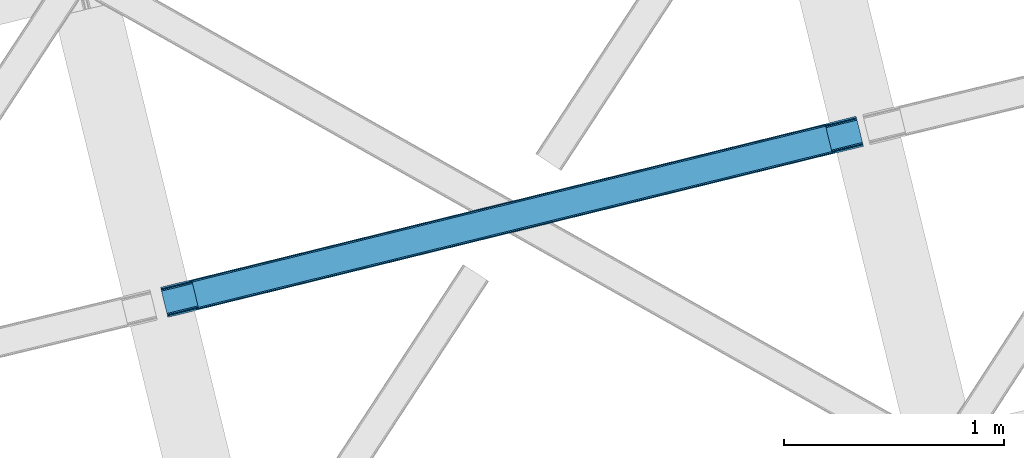
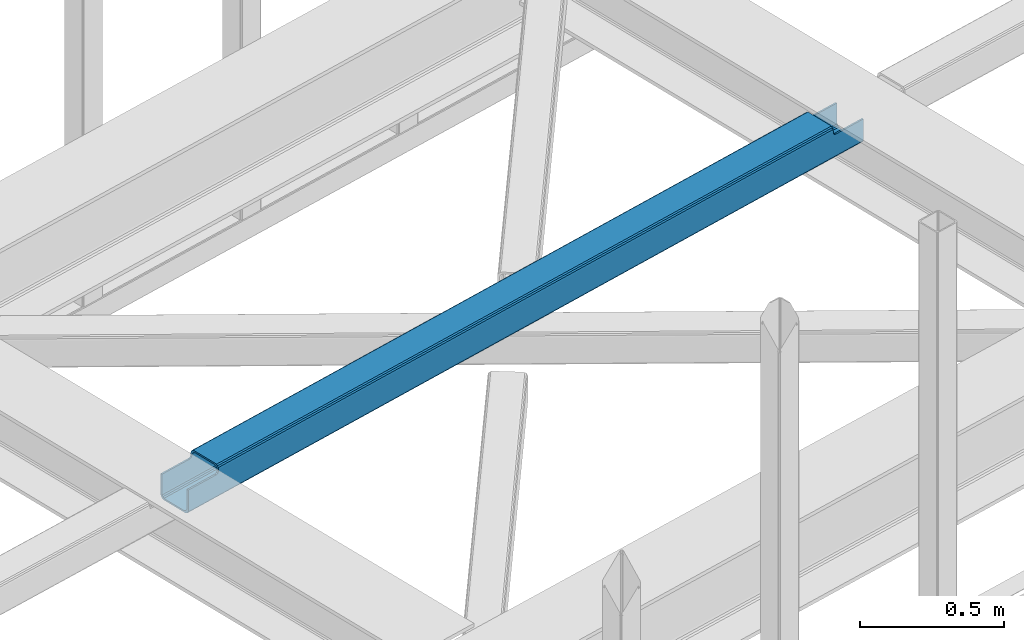
# One storey, part 34 of 67: 1 beam.
"""IFC4 building model written with IfcOpenShell, lengths in millimetres."""

from ifc_helpers import new_model, entity, si_unit, converted_unit, derived_unit, direction, frame, origin, place, context, subcontext, project, spatial, triangles, type_object, element, save


model = new_model("IFC4")

# Units and contexts
model_context = context("Model", 3, precision=0.01, world=origin(), true_north=direction((6.12303176911189e-17, 1.0)))
plan_context = context("Plan", 3, precision=0.01, world=origin(), true_north=direction((6.12303176911189e-17, 1.0)))
body_context = subcontext(model_context, "Body", "Model", "MODEL_VIEW")
ifc_project = project(units=[si_unit("LENGTHUNIT", "METRE", prefix="MILLI"), si_unit("AREAUNIT", "SQUARE_METRE"), si_unit("VOLUMEUNIT", "CUBIC_METRE"), converted_unit("PLANEANGLEUNIT", "DEGREE", entity("IfcRatioMeasure", 0.0174532925199433), si_unit("PLANEANGLEUNIT", "RADIAN"), dimensions=[0, 0, 0, 0, 0, 0, 0]), si_unit("MASSUNIT", "GRAM", prefix="KILO"), derived_unit("MASSDENSITYUNIT", [(si_unit("MASSUNIT", "GRAM", prefix="KILO"), 1), (si_unit("LENGTHUNIT", "METRE"), -3)]), derived_unit("MOMENTOFINERTIAUNIT", [(si_unit("LENGTHUNIT", "METRE"), 4)]), si_unit("TIMEUNIT", "SECOND"), si_unit("FREQUENCYUNIT", "HERTZ"), si_unit("THERMODYNAMICTEMPERATUREUNIT", "DEGREE_CELSIUS"), derived_unit("THERMALTRANSMITTANCEUNIT", [(si_unit("MASSUNIT", "GRAM", prefix="KILO"), 1), (si_unit("THERMODYNAMICTEMPERATUREUNIT", "KELVIN"), -1), (si_unit("TIMEUNIT", "SECOND"), -3)]), derived_unit("VOLUMETRICFLOWRATEUNIT", [(si_unit("LENGTHUNIT", "METRE"), 3), (si_unit("TIMEUNIT", "SECOND"), -1)]), derived_unit("MASSFLOWRATEUNIT", [(si_unit("MASSUNIT", "GRAM", prefix="KILO"), 1), (si_unit("TIMEUNIT", "SECOND"), -1)]), derived_unit("ROTATIONALFREQUENCYUNIT", [(si_unit("TIMEUNIT", "SECOND"), -1)]), si_unit("ELECTRICCURRENTUNIT", "AMPERE"), si_unit("ELECTRICVOLTAGEUNIT", "VOLT"), si_unit("POWERUNIT", "WATT"), si_unit("FORCEUNIT", "NEWTON", prefix="KILO"), si_unit("ILLUMINANCEUNIT", "LUX"), si_unit("LUMINOUSFLUXUNIT", "LUMEN"), si_unit("LUMINOUSINTENSITYUNIT", "CANDELA"), derived_unit("USERDEFINED", [(si_unit("MASSUNIT", "GRAM", prefix="KILO"), -1), (si_unit("LENGTHUNIT", "METRE"), -2), (si_unit("TIMEUNIT", "SECOND"), 3), (si_unit("LUMINOUSFLUXUNIT", "LUMEN"), 1)]), derived_unit("LINEARVELOCITYUNIT", [(si_unit("LENGTHUNIT", "METRE"), 1), (si_unit("TIMEUNIT", "SECOND"), -1)]), si_unit("PRESSUREUNIT", "PASCAL"), derived_unit("USERDEFINED", [(si_unit("LENGTHUNIT", "METRE"), -2), (si_unit("MASSUNIT", "GRAM", prefix="KILO"), 1), (si_unit("TIMEUNIT", "SECOND"), -2)]), derived_unit("LINEARFORCEUNIT", [(si_unit("MASSUNIT", "GRAM", prefix="KILO"), 1), (si_unit("LENGTHUNIT", "METRE"), 1), (si_unit("TIMEUNIT", "SECOND"), -2), (si_unit("LENGTHUNIT", "METRE"), -1)]), derived_unit("PLANARFORCEUNIT", [(si_unit("MASSUNIT", "GRAM", prefix="KILO"), 1), (si_unit("LENGTHUNIT", "METRE"), 1), (si_unit("TIMEUNIT", "SECOND"), -2), (si_unit("LENGTHUNIT", "METRE"), -2)])], contexts=[model_context, plan_context])

# Site, building, storey
site_placement = place(None, origin())
site = spatial("IfcSite", under=ifc_project, at=site_placement, CompositionType="ELEMENT")
building_placement = place(site_placement, origin())
building = spatial("IfcBuilding", under=site, at=building_placement, CompositionType="ELEMENT")
storey_placement = place(building_placement, frame((0.0, 0.0, 19800.0)))
storey = spatial("IfcBuildingStorey", under=building, at=storey_placement, CompositionType="ELEMENT", Elevation=19800.0)

# Beam
beam_type = type_object("IfcBeamType", PredefinedType="BEAM")
beam_placement = place(storey_placement, frame((-36151.9096069336, 10320.6374816895, 3967.02835693359)))
element("IfcBeam", 1, at=beam_placement, inside=storey, type_object=beam_type, ObjectType="Steel Beam", PredefinedType="BEAM", context=body_context, shape_type="Tessellation", body=[
    triangles([(3160.10943603516, 895.15698852539, 0.0), (3184.97536010742, 793.143447875977, 0.0), (4.14393310546438, 119.014828491212, 0.965057373046875), (29.012182617189, 17.0012878417965, 0.965057373046875), (3155.96550292968, 912.159439086914, 17.4989318847656), (3156.27943725586, 910.86533203125, 10.8016662597656), (0.0, 136.017279052734, 18.4639892578125), (0.316259765626455, 134.723171997071, 11.7667236328125), (3157.17938232422, 907.179510498047, 5.12526855468604), (1.21387939452688, 131.037350463868, 6.09032592773292), (3158.52348632812, 901.663568115235, 1.33247680664135), (2.5579833984375, 125.521408081055, 2.29753417968823), (3186.56130981445, 786.636868286134, 1.33247680664135), (30.5981323242158, 10.4947082519539, 2.29753417968823), (3187.90773925781, 781.12092590332, 5.12526855468604), (31.9422363281265, 4.97876586914026, 6.09032592773292), (3188.80535888672, 777.436267089844, 10.8016662597656), (32.8398559570269, 1.29410705566443, 11.7667236328125), (3189.12161865235, 776.140997314453, 17.4989318847656), (33.1561157226533, 0.0, 18.4639892578125), (2.87191772460938, 124.236602783203, 13.0898986816392), (4.21602172851271, 118.720660400391, 9.29710693359448), (5.80197143554688, 112.214080810547, 7.96463012695313), (1.97429809570167, 127.922424316406, 18.7662963867188), (0.0, 136.017279052734, 105.472631835935), (1.65803833007521, 129.216531372071, 25.4635620117188), (1.65803833007521, 129.216531372071, 105.472631835935), (28.9400939941406, 17.2966186523445, 9.29710693359448), (30.284197998044, 11.7806762695309, 13.0898986816392), (27.3541442871065, 23.8020355224617, 7.96463012695313), (31.1818176269517, 8.09485473632776, 18.7662963867188), (31.4980773925781, 6.80074768066515, 25.4635620117188), (33.1561157226533, 0.0, 105.472631835935), (31.4980773925781, 6.80074768066515, 105.472631835935), (3183.3196472168, 799.944195556642, 6.99957275390625), (3161.76747436523, 888.356240844727, 6.99957275390625), (3160.1815246582, 894.862820434571, 8.3320495605476), (3158.83742065429, 900.378762817383, 12.1248413085923), (3157.93747558594, 904.064584350586, 17.8035644531228), (3157.62354125977, 905.358691406251, 24.4985046386719), (3187.46358032226, 782.942907714843, 24.4985046386719), (3187.14732055664, 784.237014770508, 17.8035644531228), (3186.24970092774, 787.922836303711, 12.1248413085923), (3184.90559692383, 793.438778686525, 8.3320495605476), (131.782653808594, 161.216903686523, 105.472631835935), (130.124615478511, 168.018814086914, 105.472631835935), (163.280731201172, 32.0003723144528, 105.472631835935), (161.622692871089, 38.8011199951179, 105.472631835935), (3155.96550292968, 912.159439086914, 104.491296386717), (3157.62354125977, 905.358691406251, 104.491296386717), (3189.12161865235, 776.140997314453, 104.491296386717), (3187.46358032226, 782.942907714843, 104.491296386717), (3025.84321289062, 880.157904052734, 104.491296386717), (3027.5012512207, 873.357156372071, 104.491296386717), (3057.3412902832, 750.941372680665, 104.491296386717), (3058.99932861328, 744.140625, 104.491296386717), (3022.06437377929, 879.228890991211, 106.102825927734), (3023.72241210938, 872.428143310548, 106.102825927734), (3018.29018554687, 878.301040649414, 107.71435546875), (3019.94822387695, 871.500292968751, 107.71435546875), (3016.72516479492, 877.916180419923, 111.602490234374), (3018.383203125, 871.115432739258, 111.602490234374), (3015.16246948242, 877.53132019043, 115.492950439453), (3016.8205078125, 870.730572509767, 115.541784667967), (3049.88128051758, 741.898901367187, 111.602490234374), (3048.2232421875, 748.699649047852, 111.602490234374), (3046.660546875, 748.314788818359, 115.492950439453), (3048.31858520507, 741.514041137696, 115.492950439453), (3051.44630126953, 742.28376159668, 107.71435546875), (3049.78826293945, 749.084509277343, 107.71435546875), (3055.22048950195, 743.211611938477, 106.102825927734), (3053.56245117187, 750.012359619141, 106.102825927734), (140.910003662109, 163.462115478516, 112.581500244141), (142.463397216794, 163.844650268555, 116.471960449217), (139.335681152341, 163.074929809571, 108.693365478513), (135.556842041013, 162.145916748048, 107.081835937501), (170.750042724605, 41.046331787109, 112.581500244141), (169.175720214844, 40.6591461181652, 108.693365478513), (165.39920654297, 39.7301330566406, 107.081835937501), (172.303436279297, 41.4288665771492, 116.471960449217), (139.240338134761, 170.260537719727, 112.583825683592), (140.805358886719, 170.64539794922, 116.471960449217), (137.677642822266, 169.875677490234, 108.693365478513), (133.901129150392, 168.946664428711, 107.081835937501), (170.833758544919, 33.8583984375, 108.693365478513), (172.396453857422, 34.2420959472656, 112.583825683592), (173.961474609372, 34.6269561767585, 116.471960449217), (167.054919433591, 32.9293853759773, 107.081835937501), (3015.16246948242, 877.53132019043, 122.541357421873), (140.805358886719, 170.64539794922, 123.420373535155), (3048.31858520507, 741.514041137696, 122.541357421873), (173.961474609372, 34.6269561767585, 123.420373535155), (3017.13444213867, 869.436465454102, 122.239050292967), (142.77965698242, 162.55054321289, 123.118066406249), (3018.03438720703, 865.750643920899, 127.917773437501), (143.677276611328, 158.864721679687, 128.794464111328), (3019.37849121093, 860.234701538086, 131.710565185545), (145.021380615231, 153.348779296875, 132.589581298827), (3020.96444091797, 853.728121948243, 133.043041992187), (146.607330322266, 146.842199707031, 133.922058105469), (3046.34428710937, 749.608895874024, 122.239050292967), (171.98717651367, 42.7229736328136, 123.118066406249), (3042.51661376953, 765.317239379883, 133.043041992187), (3044.10256347656, 758.810659790039, 131.710565185545), (168.159503173825, 58.4301544189457, 133.922058105469), (169.745452880859, 51.9247375488285, 132.589581298827), (3045.44666748046, 753.294717407227, 127.917773437501), (171.089556884763, 46.4087951660167, 128.796789550779), (3015.47640380859, 876.237213134766, 129.238623046873), (3016.37634887695, 872.551391601563, 134.917346191407), (3017.72045288086, 867.035449218751, 138.710137939452), (3019.30640258789, 860.530032348634, 140.042614746093), (3045.75827636719, 752.009912109375, 138.710137939452), (3044.17232666015, 758.51649169922, 140.042614746093), (3047.10470581055, 746.493969726564, 134.917346191407), (3048.00232543945, 742.80814819336, 129.238623046873), (141.121618652345, 169.351290893555, 130.117639160155), (142.019238281246, 165.665469360352, 135.796362304685), (143.363342285156, 160.149526977539, 139.589154052734), (144.949291992183, 153.642947387696, 140.921630859375), (171.403491210935, 45.1228271484379, 139.589154052734), (169.817541503908, 51.6294067382823, 140.921630859375), (172.747595214845, 39.6068847656261, 135.796362304685), (173.645214843746, 35.9222259521484, 130.117639160155)], [[1, 2, 3], [4, 3, 2], [5, 6, 7], [8, 7, 6], [6, 9, 8], [10, 8, 9], [9, 11, 10], [12, 10, 11], [11, 1, 12], [3, 12, 1], [2, 13, 4], [14, 4, 13], [13, 15, 14], [16, 14, 15], [15, 17, 16], [18, 16, 17], [17, 19, 18], [20, 18, 19], [21, 8, 10], [21, 10, 12], [21, 12, 22], [23, 3, 4], [3, 22, 12], [23, 22, 3], [8, 24, 7], [25, 26, 27], [25, 7, 26], [8, 21, 24], [24, 26, 7], [28, 14, 29], [4, 30, 23], [28, 4, 14], [4, 28, 30], [16, 18, 29], [29, 14, 16], [18, 31, 29], [32, 31, 20], [20, 31, 18], [32, 33, 34], [20, 33, 32], [35, 36, 23], [23, 30, 35], [36, 37, 22], [22, 23, 36], [37, 38, 21], [21, 22, 37], [38, 39, 24], [24, 21, 38], [39, 40, 26], [26, 24, 39], [41, 42, 31], [31, 32, 41], [42, 43, 29], [29, 31, 42], [43, 44, 28], [28, 29, 43], [44, 35, 30], [30, 28, 44], [45, 46, 25], [25, 27, 45], [47, 48, 34], [34, 33, 47], [6, 5, 39], [49, 40, 5], [40, 49, 50], [40, 39, 5], [38, 6, 39], [38, 9, 6], [11, 38, 37], [38, 11, 9], [37, 1, 11], [1, 36, 2], [36, 1, 37], [17, 43, 42], [42, 19, 17], [42, 41, 19], [41, 51, 19], [52, 51, 41], [44, 43, 13], [2, 44, 13], [35, 2, 36], [2, 35, 44], [13, 43, 15], [15, 43, 17], [50, 49, 53], [53, 54, 50], [51, 52, 55], [55, 56, 51], [54, 53, 57], [57, 58, 54], [58, 57, 59], [59, 60, 58], [60, 59, 61], [61, 62, 60], [62, 61, 63], [63, 64, 62], [65, 66, 67], [67, 68, 65], [69, 70, 66], [66, 65, 69], [71, 72, 70], [70, 69, 71], [56, 55, 72], [72, 71, 56], [40, 60, 26], [62, 73, 60], [58, 60, 40], [62, 64, 74], [40, 54, 58], [54, 40, 50], [26, 60, 75], [75, 60, 73], [74, 73, 62], [75, 76, 26], [45, 26, 76], [26, 45, 27], [70, 41, 32], [72, 41, 70], [52, 41, 55], [72, 55, 41], [67, 66, 77], [66, 70, 77], [78, 70, 32], [32, 79, 78], [48, 79, 32], [32, 34, 48], [78, 77, 70], [77, 80, 67], [81, 73, 74], [74, 82, 81], [73, 81, 83], [76, 84, 46], [46, 45, 76], [75, 83, 84], [84, 76, 75], [83, 75, 73], [78, 85, 86], [86, 87, 80], [80, 77, 86], [86, 77, 78], [85, 78, 79], [79, 88, 85], [88, 79, 48], [48, 47, 88], [59, 5, 7], [57, 5, 59], [49, 5, 53], [57, 53, 5], [63, 61, 81], [61, 59, 83], [89, 63, 82], [83, 59, 7], [7, 84, 83], [46, 84, 7], [7, 25, 46], [81, 82, 63], [82, 90, 89], [83, 81, 61], [19, 69, 20], [68, 86, 65], [69, 65, 85], [68, 91, 87], [71, 69, 19], [19, 51, 56], [56, 71, 19], [20, 69, 85], [86, 68, 87], [92, 87, 91], [86, 85, 65], [20, 85, 88], [88, 47, 20], [33, 20, 47], [93, 94, 74], [74, 64, 93], [93, 95, 94], [96, 94, 95], [95, 97, 96], [98, 96, 97], [97, 99, 98], [100, 98, 99], [80, 101, 67], [80, 102, 101], [103, 104, 105], [106, 105, 104], [104, 107, 106], [108, 106, 107], [107, 101, 108], [102, 108, 101], [99, 103, 100], [105, 100, 103], [95, 109, 110], [95, 110, 111], [95, 111, 97], [99, 112, 103], [112, 97, 111], [99, 97, 112], [109, 93, 89], [64, 89, 93], [64, 63, 89], [109, 95, 93], [104, 113, 107], [114, 103, 112], [104, 114, 113], [114, 104, 103], [115, 116, 107], [107, 113, 115], [116, 101, 107], [67, 101, 91], [91, 101, 116], [91, 68, 67], [96, 117, 118], [96, 118, 119], [96, 119, 98], [100, 120, 105], [120, 98, 119], [100, 98, 120], [117, 94, 90], [74, 90, 94], [74, 82, 90], [117, 96, 94], [106, 121, 108], [122, 105, 120], [106, 122, 121], [122, 106, 105], [123, 124, 108], [108, 121, 123], [124, 102, 108], [80, 102, 92], [92, 102, 124], [92, 87, 80], [112, 111, 119], [119, 120, 112], [111, 110, 118], [118, 119, 111], [110, 109, 117], [117, 118, 110], [109, 89, 90], [90, 117, 109], [114, 112, 120], [120, 122, 114], [91, 116, 124], [124, 92, 91], [116, 115, 123], [123, 124, 116], [115, 113, 121], [121, 123, 115], [113, 114, 122], [122, 121, 113]]),
])

save(model, "model.ifc")
